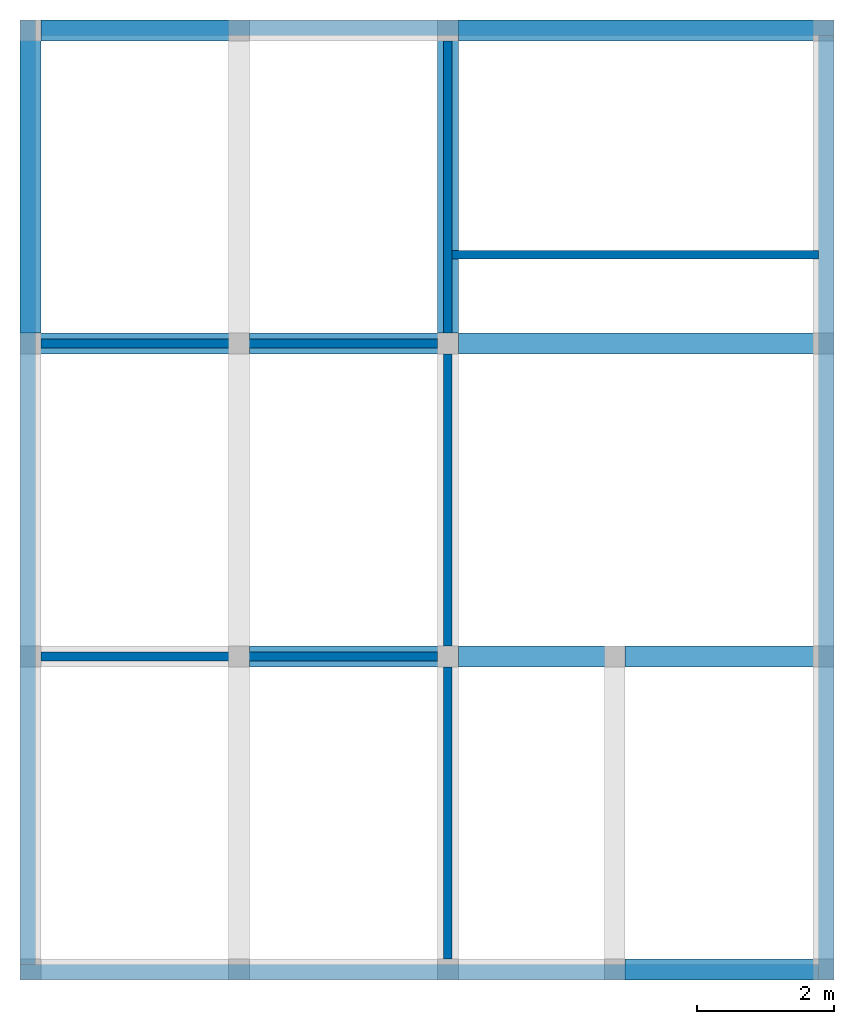
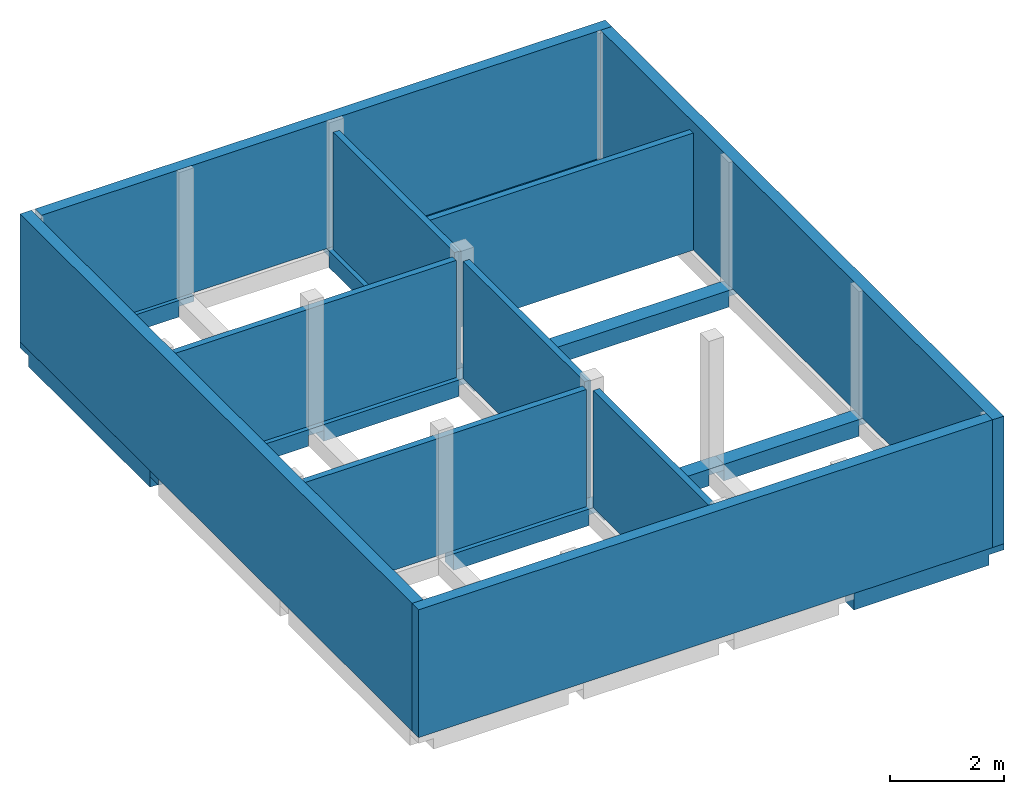
# One storey, part 2 of 2: 11 beams, 10 walls.
"""IFC2X3 building model written with IfcOpenShell, lengths in feet."""

from ifc_helpers import new_model, entity, si_unit, converted_unit, derived_unit, direction, frame, frame_2d, origin, place, context, subcontext, project, spatial, rectangle, extrude, faceted_brep, material, layer, layer_set, layer_usage, type_object, element, save


model = new_model("IFC2X3")

# Units and contexts
model_context = context("Model", 3, precision=0.0001, world=origin(), true_north=direction((6.123031769111886e-17, 1.0)))
body_context = subcontext(model_context, "Body", "Model", "MODEL_VIEW")
ifc_project = project(units=[converted_unit("LENGTHUNIT", "FOOT", entity("IfcLengthMeasure", 0.3048), si_unit("LENGTHUNIT", "METRE"), dimensions=[1, 0, 0, 0, 0, 0, 0]), converted_unit("AREAUNIT", "SQUARE FOOT", entity("IfcAreaMeasure", 0.09290304), si_unit("AREAUNIT", "SQUARE_METRE"), dimensions=[2, 0, 0, 0, 0, 0, 0]), converted_unit("VOLUMEUNIT", "CUBIC FOOT", entity("IfcVolumeMeasure", 0.028316846592000004), si_unit("VOLUMEUNIT", "CUBIC_METRE"), dimensions=[3, 0, 0, 0, 0, 0, 0]), converted_unit("PLANEANGLEUNIT", "DEGREE", entity("IfcPlaneAngleMeasure", 0.017453292519943278), si_unit("PLANEANGLEUNIT", "RADIAN"), dimensions=[0, 0, 0, 0, 0, 0, 0]), si_unit("MASSUNIT", "GRAM", prefix="KILO"), derived_unit("MASSDENSITYUNIT", [(si_unit("MASSUNIT", "GRAM", prefix="KILO"), 1), (si_unit("LENGTHUNIT", "METRE"), -3)]), derived_unit("IONCONCENTRATIONUNIT", [(si_unit("MASSUNIT", "GRAM", prefix="KILO"), 1), (si_unit("LENGTHUNIT", "METRE"), -3)]), derived_unit("MOMENTOFINERTIAUNIT", [(si_unit("LENGTHUNIT", "METRE"), 4)]), si_unit("TIMEUNIT", "SECOND"), si_unit("FREQUENCYUNIT", "HERTZ"), si_unit("THERMODYNAMICTEMPERATUREUNIT", "DEGREE_CELSIUS"), derived_unit("THERMALTRANSMITTANCEUNIT", [(si_unit("MASSUNIT", "GRAM", prefix="KILO"), 1), (si_unit("THERMODYNAMICTEMPERATUREUNIT", "KELVIN"), -1), (si_unit("TIMEUNIT", "SECOND"), -3)]), derived_unit("THERMALCONDUCTANCEUNIT", [(si_unit("MASSUNIT", "GRAM", prefix="KILO"), 1), (si_unit("THERMODYNAMICTEMPERATUREUNIT", "KELVIN"), -1), (si_unit("TIMEUNIT", "SECOND"), -3), (si_unit("LENGTHUNIT", "METRE"), 1)]), derived_unit("VOLUMETRICFLOWRATEUNIT", [(si_unit("LENGTHUNIT", "METRE"), 3), (si_unit("TIMEUNIT", "SECOND"), -1)]), derived_unit("MASSFLOWRATEUNIT", [(si_unit("MASSUNIT", "GRAM", prefix="KILO"), 1), (si_unit("TIMEUNIT", "SECOND"), -1)]), derived_unit("ROTATIONALFREQUENCYUNIT", [(si_unit("TIMEUNIT", "SECOND"), -1)]), si_unit("ELECTRICCURRENTUNIT", "AMPERE"), si_unit("ELECTRICVOLTAGEUNIT", "VOLT"), si_unit("POWERUNIT", "WATT"), converted_unit("FORCEUNIT", "KIP", entity("IfcForceMeasure", 2.088543423315013e-05), si_unit("FORCEUNIT", "NEWTON"), dimensions=[1, 1, -2, 0, 0, 0, 0]), si_unit("ILLUMINANCEUNIT", "LUX"), si_unit("LUMINOUSFLUXUNIT", "LUMEN"), si_unit("LUMINOUSINTENSITYUNIT", "CANDELA"), si_unit("ENERGYUNIT", "JOULE"), derived_unit("USERDEFINED", [(si_unit("MASSUNIT", "GRAM", prefix="KILO"), -1), (si_unit("LENGTHUNIT", "METRE"), -2), (si_unit("TIMEUNIT", "SECOND"), 3), (si_unit("LUMINOUSFLUXUNIT", "LUMEN"), 1)]), derived_unit("USERDEFINED", [(si_unit("MASSUNIT", "GRAM", prefix="KILO"), 1), (si_unit("TIMEUNIT", "SECOND"), -3), (si_unit("LENGTHUNIT", "METRE"), 3), (si_unit("ELECTRICCURRENTUNIT", "AMPERE"), -2)]), derived_unit("SOUNDPOWERUNIT", [(si_unit("MASSUNIT", "GRAM", prefix="KILO"), 1), (si_unit("TIMEUNIT", "SECOND"), -3), (si_unit("LENGTHUNIT", "METRE"), 2)]), derived_unit("SOUNDPRESSUREUNIT", [(si_unit("MASSUNIT", "GRAM", prefix="KILO"), 1), (si_unit("LENGTHUNIT", "METRE"), -1), (si_unit("TIMEUNIT", "SECOND"), -2)]), derived_unit("LINEARVELOCITYUNIT", [(si_unit("LENGTHUNIT", "METRE"), 1), (si_unit("TIMEUNIT", "SECOND"), -1)]), si_unit("PRESSUREUNIT", "PASCAL"), derived_unit("USERDEFINED", [(si_unit("MASSUNIT", "GRAM", prefix="KILO"), 1), (si_unit("LENGTHUNIT", "METRE"), -2), (si_unit("TIMEUNIT", "SECOND"), -2)]), derived_unit("LINEARFORCEUNIT", [(si_unit("MASSUNIT", "GRAM", prefix="KILO"), 1), (si_unit("TIMEUNIT", "SECOND"), -2)]), derived_unit("PLANARFORCEUNIT", [(si_unit("MASSUNIT", "GRAM", prefix="KILO"), 1), (si_unit("LENGTHUNIT", "METRE"), -1), (si_unit("TIMEUNIT", "SECOND"), -2)]), derived_unit("SPECIFICHEATCAPACITYUNIT", [(si_unit("THERMODYNAMICTEMPERATUREUNIT", "KELVIN"), -1), (si_unit("LENGTHUNIT", "METRE"), 2), (si_unit("TIMEUNIT", "SECOND"), -2)]), derived_unit("HEATFLUXDENSITYUNIT", [(si_unit("MASSUNIT", "GRAM", prefix="KILO"), 1), (si_unit("TIMEUNIT", "SECOND"), -3)]), derived_unit("HEATINGVALUEUNIT", [(si_unit("LENGTHUNIT", "METRE"), 2), (si_unit("TIMEUNIT", "SECOND"), -2)]), derived_unit("VAPORPERMEABILITYUNIT", [(si_unit("LENGTHUNIT", "METRE"), -1), (si_unit("TIMEUNIT", "SECOND"), 1)]), derived_unit("DYNAMICVISCOSITYUNIT", [(si_unit("MASSUNIT", "GRAM", prefix="KILO"), 1), (si_unit("TIMEUNIT", "SECOND"), -1), (si_unit("LENGTHUNIT", "METRE"), -1)]), derived_unit("THERMALEXPANSIONCOEFFICIENTUNIT", [(si_unit("THERMODYNAMICTEMPERATUREUNIT", "KELVIN"), -1)]), derived_unit("MODULUSOFELASTICITYUNIT", [(si_unit("MASSUNIT", "GRAM", prefix="KILO"), 1), (si_unit("LENGTHUNIT", "METRE"), -1), (si_unit("TIMEUNIT", "SECOND"), -2)]), derived_unit("ISOTHERMALMOISTURECAPACITYUNIT", [(si_unit("LENGTHUNIT", "METRE"), 3), (si_unit("MASSUNIT", "GRAM", prefix="KILO"), -1)]), derived_unit("MOISTUREDIFFUSIVITYUNIT", [(si_unit("TIMEUNIT", "SECOND"), -1), (si_unit("LENGTHUNIT", "METRE"), 2)]), derived_unit("MASSPERLENGTHUNIT", [(si_unit("MASSUNIT", "GRAM", prefix="KILO"), 1), (si_unit("LENGTHUNIT", "METRE"), -1)]), derived_unit("THERMALRESISTANCEUNIT", [(si_unit("MASSUNIT", "GRAM", prefix="KILO"), -1), (si_unit("TIMEUNIT", "SECOND"), 3), (si_unit("THERMODYNAMICTEMPERATUREUNIT", "KELVIN"), 1)]), derived_unit("ACCELERATIONUNIT", [(si_unit("LENGTHUNIT", "METRE"), 1), (si_unit("TIMEUNIT", "SECOND"), -2)]), derived_unit("ANGULARVELOCITYUNIT", [(si_unit("TIMEUNIT", "SECOND"), -1), (si_unit("PLANEANGLEUNIT", "RADIAN"), 1)]), derived_unit("LINEARSTIFFNESSUNIT", [(si_unit("MASSUNIT", "GRAM", prefix="KILO"), 1), (si_unit("TIMEUNIT", "SECOND"), -2)]), derived_unit("WARPINGCONSTANTUNIT", [(si_unit("LENGTHUNIT", "METRE"), 6)]), derived_unit("LINEARMOMENTUNIT", [(si_unit("MASSUNIT", "GRAM", prefix="KILO"), 1), (si_unit("LENGTHUNIT", "METRE"), 1), (si_unit("TIMEUNIT", "SECOND"), -2)]), derived_unit("TORQUEUNIT", [(si_unit("MASSUNIT", "GRAM", prefix="KILO"), 1), (si_unit("LENGTHUNIT", "METRE"), 2), (si_unit("TIMEUNIT", "SECOND"), -2)])], contexts=[model_context])

# Site, building, storey
site_placement = place(None, origin())
site = spatial("IfcSite", under=ifc_project, at=site_placement, CompositionType="ELEMENT")
building_placement = place(site_placement, origin())
building = spatial("IfcBuilding", under=site, at=building_placement, CompositionType="ELEMENT")
storey_placement = place(building_placement, frame((0.0, 0.0, 9.416666666668288)))
storey = spatial("IfcBuildingStorey", under=building, at=storey_placement, Name="First Floor", CompositionType="ELEMENT", Elevation=9.416666666668288)

# Beams
ifc_material_1 = material(Name="Concrete, Cast-in-Place gray")
beam_type = type_object("IfcBeamType", PredefinedType="NOTDEFINED")
for number, where in (
    (1, (38.37447801916311, -50.34124484724908, -1.1666666666666714)),
    (2, (20.374478019163327, -35.34124484724902, -1.1666666666666714)),
):
    element("IfcBeam", number, at=place(storey_placement, frame(where)), inside=storey, type_object=beam_type, material=ifc_material_1, context=body_context, shape_type="Brep", body=[
        faceted_brep([(10.0, 0.0, 1.1666666666666643), (10.0, 1.0, 1.1666666666666643), (9.0, 1.0, 1.1666666666666643), (0.0, 1.0, 1.1666666666666643), (0.0, 0.0, 1.1666666666666643), (9.0, 0.0, 1.1666666666666643), (0.0, 0.0, 0.7499999999983835), (0.0, 0.0, 0.0), (9.0, 0.0, 0.0), (9.0, 0.0, 0.7499999999983835), (10.0, 0.0, 0.7499999999983835), (0.0, 1.0, 0.0), (9.0, 1.0, 0.0), (10.0, 1.0, 0.7499999999983835), (9.0, 1.0, 0.7499999999983835), (0.0, 1.0, 0.7499999999983835)], [[[0, 1, 2, 3, 4, 5]], [[0, 5, 4, 6, 7, 8, 9, 10]], [[7, 11, 12, 8]], [[3, 2, 1, 13, 14, 12, 11, 15]], [[1, 0, 10, 13]], [[4, 3, 15, 11, 7, 6]], [[14, 9, 8, 12]], [[9, 14, 13, 10]]]),
    ])
beam_1_placement = place(storey_placement, frame((30.37447801916315, -35.34124484724903, -1.1666666666666732)))
element("IfcBeam", 3, at=beam_1_placement, inside=storey, type_object=beam_type, material=ifc_material_1, context=body_context, shape_type="Brep", body=[
    faceted_brep([(8.0, 0.0, 1.166666666666666), (8.0, 1.0, 1.166666666666666), (7.0, 1.0, 1.166666666666666), (0.0, 1.0, 1.166666666666666), (0.0, 0.0, 1.1666666666666679), (7.0, 0.0, 1.1666666666666679), (0.0, 0.0, 0.7499999999983853), (0.0, 0.0, 0.0), (7.0, 0.0, 0.0), (7.0, 0.0, 0.7499999999983853), (8.0, 0.0, 0.7499999999983853), (0.0, 1.0, 0.0), (7.0, 1.0, 0.0), (8.0, 1.0, 0.7499999999983853), (7.0, 1.0, 0.7499999999983853), (0.0, 1.0, 0.7499999999983853)], [[[0, 1, 2, 3, 4, 5]], [[0, 5, 4, 6, 7, 8, 9, 10]], [[7, 11, 12, 8]], [[3, 2, 1, 13, 14, 12, 11, 15]], [[1, 0, 10, 13]], [[4, 3, 15, 11, 7, 6]], [[14, 9, 8, 12]], [[9, 14, 13, 10]]]),
])
beam_2_placement = place(storey_placement, frame((38.37447801916313, -35.34124484724908, -1.1666666666666714)))
element("IfcBeam", 4, at=beam_2_placement, inside=storey, type_object=beam_type, material=ifc_material_1, context=body_context, shape_type="Brep", body=[
    faceted_brep([(10.0, 0.0, 1.1666666666666643), (10.0, 1.0, 1.1666666666666643), (9.0, 1.0, 1.1666666666666643), (0.0, 1.0, 1.1666666666666643), (0.0, 0.0, 1.1666666666666643), (9.0, 0.0, 1.1666666666666643), (0.0, 0.0, 0.7499999999983835), (0.0, 0.0, 0.0), (9.0, 0.0, 0.0), (9.0, 0.0, 0.7499999999983835), (10.0, 0.0, 0.7499999999983835), (0.0, 1.0, 0.0), (9.0, 1.0, 0.0), (10.0, 1.0, 0.7499999999983835), (9.0, 1.0, 0.7499999999983835), (0.0, 1.0, 0.7499999999983835)], [[[0, 1, 2, 3, 4, 5]], [[0, 5, 4, 6, 7, 8, 9, 10]], [[7, 11, 12, 8]], [[3, 2, 1, 13, 14, 12, 11, 15]], [[1, 0, 10, 13]], [[4, 3, 15, 11, 7, 6]], [[14, 9, 8, 12]], [[9, 14, 13, 10]]]),
])
beam_3_placement = place(storey_placement, frame((9.374478019163147, -20.341244847248984, -1.1666666666666714)))
element("IfcBeam", 5, at=beam_3_placement, inside=storey, type_object=beam_type, material=ifc_material_1, context=body_context, shape_type="Brep", body=[
    faceted_brep([(11.0, 0.0, 1.1666666666666643), (11.0, 1.0, 1.1666666666666643), (10.0, 1.0, 1.1666666666666643), (1.0, 1.0, 1.1666666666666643), (0.0, 1.0, 1.1666666666666643), (0.0, 0.0, 1.1666666666666643), (1.0, 0.0, 1.1666666666666643), (10.0, 0.0, 1.1666666666666643), (0.0, 0.0, 0.7499999999983835), (1.0, 0.0, 0.7499999999983835), (1.0, 0.0, 0.0), (10.0, 0.0, 0.0), (10.0, 0.0, 0.7499999999983835), (11.0, 0.0, 0.7499999999983835), (1.0, 1.0, 0.0), (10.0, 1.0, 0.0), (11.0, 1.0, 0.7499999999983835), (10.0, 1.0, 0.7499999999983835), (1.0, 1.0, 0.7499999999983835), (0.0, 1.0, 0.7499999999983835)], [[[0, 1, 2, 3, 4, 5, 6, 7]], [[0, 7, 6, 5, 8, 9, 10, 11, 12, 13]], [[10, 14, 15, 11]], [[4, 3, 2, 1, 16, 17, 15, 14, 18, 19]], [[1, 0, 13, 16]], [[5, 4, 19, 8]], [[9, 18, 14, 10]], [[18, 9, 8, 19]], [[17, 12, 11, 15]], [[12, 17, 16, 13]]]),
])
beam_4_placement = place(storey_placement, frame((20.374478019163355, -20.341244847249012, -1.1666666666666714)))
element("IfcBeam", 6, at=beam_4_placement, inside=storey, type_object=beam_type, material=ifc_material_1, context=body_context, shape_type="Brep", body=[
    faceted_brep([(10.0, 0.0, 1.1666666666666643), (10.0, 1.0, 1.1666666666666643), (9.0, 1.0, 1.1666666666666643), (0.0, 1.0, 1.1666666666666643), (0.0, 0.0, 1.1666666666666643), (9.0, 0.0, 1.1666666666666643), (0.0, 0.0, 0.7499999999983835), (0.0, 0.0, 0.0), (9.0, 0.0, 0.0), (9.0, 0.0, 0.7499999999983835), (10.0, 0.0, 0.7499999999983835), (0.0, 1.0, 0.0), (9.0, 1.0, 0.0), (10.0, 1.0, 0.7499999999983835), (9.0, 1.0, 0.7499999999983835), (0.0, 1.0, 0.7499999999983835)], [[[0, 1, 2, 3, 4, 5]], [[0, 5, 4, 6, 7, 8, 9, 10]], [[7, 11, 12, 8]], [[3, 2, 1, 13, 14, 12, 11, 15]], [[1, 0, 10, 13]], [[4, 3, 15, 11, 7, 6]], [[14, 9, 8, 12]], [[9, 14, 13, 10]]]),
])
beam_5_placement = place(storey_placement, frame((30.374478019163178, -20.341244847249072, -1.1666666666666732)))
element("IfcBeam", 7, at=beam_5_placement, inside=storey, type_object=beam_type, material=ifc_material_1, context=body_context, shape_type="Brep", body=[
    faceted_brep([(18.0, 0.0, 1.166666666666666), (18.0, 1.0, 1.166666666666666), (17.0, 1.0, 1.166666666666666), (0.0, 1.0, 1.166666666666666), (0.0, 0.0, 1.1666666666666679), (17.0, 0.0, 1.1666666666666679), (0.0, 0.0, 0.7499999999983853), (0.0, 0.0, 0.0), (17.0, 0.0, 0.0), (17.0, 0.0, 0.7499999999983853), (18.0, 0.0, 0.7499999999983853), (0.0, 1.0, 0.0), (17.0, 1.0, 0.0), (18.0, 1.0, 0.7499999999983853), (17.0, 1.0, 0.7499999999983853), (0.0, 1.0, 0.7499999999983853)], [[[0, 1, 2, 3, 4, 5]], [[0, 5, 4, 6, 7, 8, 9, 10]], [[7, 11, 12, 8]], [[3, 2, 1, 13, 14, 12, 11, 15]], [[1, 0, 10, 13]], [[4, 3, 15, 11, 7, 6]], [[14, 9, 8, 12]], [[9, 14, 13, 10]]]),
])
for number, where, z_axis, x_axis in (
    (8, (9.374478019162256, -19.34124484724894, -1.1666666666666732), (0.0, 0.0, 1.0), (0.0, -1.0, 0.0)),
    (9, (29.374478019162254, -19.341244847249, -1.1666666666666732), (0.0, 0.0, 1.0), (0.0, -1.0, 0.0)),
):
    element("IfcBeam", number, at=place(storey_placement, frame(where, z_axis=z_axis, x_axis=x_axis)), inside=storey, type_object=beam_type, material=ifc_material_1, context=body_context, shape_type="Brep", body=[
        faceted_brep([(-15.0, 1.0, 1.166666666666666), (-15.0, 0.0, 1.1666666666666679), (-14.0, 0.0, 1.1666666666666679), (0.0, 0.0, 1.166666666666666), (0.0, 1.0, 1.166666666666666), (-14.0, 1.0, 1.166666666666666), (-15.0, 0.0, 0.7499999999983853), (-14.0, 0.0, 0.7499999999983853), (-14.0, 0.0, 0.0), (0.0, 0.0, 0.0), (0.0, 0.0, 0.7499999999983853), (0.0, 1.0, 0.0), (-14.0, 1.0, 0.0), (0.0, 1.0, 0.7499999999983853), (-14.0, 1.0, 0.7499999999983853), (-15.0, 1.0, 0.7499999999983853)], [[[0, 1, 2, 3, 4, 5]], [[3, 2, 1, 6, 7, 8, 9, 10]], [[11, 9, 8, 12]], [[0, 5, 4, 13, 11, 12, 14, 15]], [[1, 0, 15, 6]], [[4, 3, 10, 9, 11, 13]], [[7, 14, 12, 8]], [[14, 7, 6, 15]]]),
    ])
beam_6_placement = place(storey_placement, frame((10.374478019163183, -5.341244847248929, -1.1666666666666714)))
element("IfcBeam", 10, at=beam_6_placement, inside=storey, type_object=beam_type, material=ifc_material_1, context=body_context, shape_type="Brep", body=[
    faceted_brep([(10.0, 0.0, 1.1666666666666643), (10.0, 1.0, 1.1666666666666643), (9.0, 1.0, 1.1666666666666643), (0.0, 1.0, 1.1666666666666643), (0.0, 0.0, 1.1666666666666643), (9.0, 0.0, 1.1666666666666643), (0.0, 0.0, 0.7499999999983835), (0.0, 0.0, 0.0), (9.0, 0.0, 0.0), (9.0, 0.0, 0.7499999999983835), (10.0, 0.0, 0.7499999999983835), (0.0, 1.0, 0.0), (9.0, 1.0, 0.0), (10.0, 1.0, 0.7499999999983835), (9.0, 1.0, 0.7499999999983835), (0.0, 1.0, 0.7499999999983835)], [[[0, 1, 2, 3, 4, 5]], [[0, 5, 4, 6, 7, 8, 9, 10]], [[7, 11, 12, 8]], [[3, 2, 1, 13, 14, 12, 11, 15]], [[1, 0, 10, 13]], [[4, 3, 15, 11, 7, 6]], [[14, 9, 8, 12]], [[9, 14, 13, 10]]]),
])
beam_7_placement = place(storey_placement, frame((30.374478019163202, -5.341244847249021, -1.1666666666666732)))
element("IfcBeam", 11, at=beam_7_placement, inside=storey, type_object=beam_type, material=ifc_material_1, context=body_context, shape_type="Brep", body=[
    faceted_brep([(18.0, 0.0, 1.166666666666666), (18.0, 1.0, 1.166666666666666), (17.0, 1.0, 1.166666666666666), (0.0, 1.0, 1.166666666666666), (0.0, 0.0, 1.1666666666666679), (17.0, 0.0, 1.1666666666666679), (0.0, 0.0, 0.7499999999983853), (0.0, 0.0, 0.0), (17.0, 0.0, 0.0), (17.0, 0.0, 0.7499999999983853), (18.0, 0.0, 0.7499999999983853), (0.0, 1.0, 0.0), (17.0, 1.0, 0.0), (18.0, 1.0, 0.7499999999983853), (17.0, 1.0, 0.7499999999983853), (0.0, 1.0, 0.7499999999983853)], [[[0, 1, 2, 3, 4, 5]], [[0, 5, 4, 6, 7, 8, 9, 10]], [[7, 11, 12, 8]], [[3, 2, 1, 13, 14, 12, 11, 15]], [[1, 0, 10, 13]], [[4, 3, 15, 11, 7, 6]], [[14, 9, 8, 12]], [[9, 14, 13, 10]]]),
])

# Walls
ifc_material_2 = material(Name="Default Wall")
ifc_layer_1 = layer(ifc_material_2, 0.75)
ifc_layer_set_1 = layer_set([ifc_layer_1])
ifc_layer_usage_1 = layer_usage(ifc_layer_set_1, "AXIS2", "NEGATIVE", 0.375)
wall_type_1 = type_object("IfcWallType", PredefinedType="STANDARD", material=ifc_layer_set_1)
wall_1_placement = place(storey_placement, frame((10.37447801916223, -4.716244847248886, 0.0)))
element("IfcWallStandardCase", 12, at=wall_1_placement, inside=storey, type_object=wall_type_1, material=ifc_layer_usage_1, context=body_context, shape_type="SweptSolid", body=[
    extrude(rectangle(XDim=38.00000000000001, YDim=0.75, at=frame_2d((19.000000000000004, 0.0), x_axis=(-1.0, 0.0))), origin(), (0.0, 0.0, 1.0), 8.999999999998618),
])
wall_2_placement = place(storey_placement, frame((47.99947801916224, -5.091244847249007, 0.0), z_axis=(0.0, 0.0, 1.0), x_axis=(0.0, -1.0, 0.0)))
element("IfcWallStandardCase", 13, at=wall_2_placement, inside=storey, type_object=wall_type_1, material=ifc_layer_usage_1, context=body_context, shape_type="SweptSolid", body=[
    extrude(rectangle(XDim=45.25000000000005, YDim=0.75, at=frame_2d((22.625000000000025, -5.828670879282072e-16), x_axis=(-1.0, 0.0))), origin(), (0.0, 0.0, 1.0), 8.999999999998618),
])
wall_3_placement = place(storey_placement, frame((47.62447801916217, -49.96624484724906, 0.0), z_axis=(0.0, 0.0, 1.0), x_axis=(-1.0, 0.0, 0.0)))
element("IfcWallStandardCase", 14, at=wall_3_placement, inside=storey, type_object=wall_type_1, material=ifc_layer_usage_1, context=body_context, shape_type="SweptSolid", body=[
    extrude(rectangle(XDim=38.25000000000001, YDim=0.75, at=frame_2d((19.125000000000004, -1.2212453270876722e-15), x_axis=(-1.0, 0.0))), origin(), (0.0, 0.0, 1.0), 8.999999999998618),
])
wall_4_placement = place(storey_placement, frame((9.749478019162163, -49.59124484724893, 0.0), z_axis=(0.0, 0.0, 1.0), x_axis=(0.0, 1.0, 0.0)))
element("IfcWallStandardCase", 15, at=wall_4_placement, inside=storey, type_object=wall_type_1, material=ifc_layer_usage_1, context=body_context, shape_type="SweptSolid", body=[
    extrude(rectangle(XDim=45.25000000000005, YDim=0.75, at=frame_2d((22.625000000000025, 2.7755575615628914e-16), x_axis=(-1.0, 0.0))), origin(), (0.0, 0.0, 1.0), 8.999999999998618),
])
ifc_layer_2 = layer(ifc_material_2, 0.4166666666666667)
ifc_layer_set_2 = layer_set([ifc_layer_2])
ifc_layer_usage_2 = layer_usage(ifc_layer_set_2, "AXIS2", "NEGATIVE", 0.20833333333333334)
wall_type_2 = type_object("IfcWallType", PredefinedType="STANDARD", material=ifc_layer_set_2)
wall_5_placement = place(storey_placement, frame((10.37447801916221, -19.841244847248937, 0.0)))
element("IfcWallStandardCase", 16, at=wall_5_placement, inside=storey, type_object=wall_type_2, material=ifc_layer_usage_2, context=body_context, shape_type="SweptSolid", body=[
    extrude(rectangle(XDim=19.0, YDim=0.4166666666666643, at=frame_2d((9.5, 0.0), x_axis=(-1.0, 0.0))), origin(), (0.0, 0.0, 1.0), 8.249999999998618),
])
wall_6_placement = place(storey_placement, frame((29.87447801916221, -19.341244847248994, 0.0), z_axis=(0.0, 0.0, 1.0), x_axis=(0.0, 1.0, 0.0)))
element("IfcWallStandardCase", 17, at=wall_6_placement, inside=storey, type_object=wall_type_2, material=ifc_layer_usage_2, context=body_context, shape_type="SweptSolid", body=[
    extrude(rectangle(XDim=14.000000000000046, YDim=0.4166666666666643, at=frame_2d((7.000000000000023, 0.0), x_axis=(-1.0, 0.0))), origin(), (0.0, 0.0, 1.0), 8.249999999998618),
])
wall_7_placement = place(storey_placement, frame((29.87447801916221, -20.341244847249, 0.0), z_axis=(0.0, 0.0, 1.0), x_axis=(0.0, -1.0, 0.0)))
element("IfcWallStandardCase", 18, at=wall_7_placement, inside=storey, type_object=wall_type_2, material=ifc_layer_usage_2, context=body_context, shape_type="SweptSolid", body=[
    extrude(rectangle(XDim=13.999999999999986, YDim=0.4166666666666643, at=frame_2d((6.999999999999993, 0.0), x_axis=(-1.0, 0.0))), origin(), (0.0, 0.0, 1.0), 8.249999999998618),
])
wall_8_placement = place(storey_placement, frame((29.37447801916219, -34.841244847248994, 0.0), z_axis=(0.0, 0.0, 1.0), x_axis=(-1.0, 0.0, 0.0)))
element("IfcWallStandardCase", 19, at=wall_8_placement, inside=storey, type_object=wall_type_2, material=ifc_layer_usage_2, context=body_context, shape_type="SweptSolid", body=[
    extrude(rectangle(XDim=19.000000000000007, YDim=0.4166666666666714, at=frame_2d((9.500000000000004, 0.0), x_axis=(-1.0, 0.0))), origin(), (0.0, 0.0, 1.0), 8.249999999998618),
])
wall_9_placement = place(storey_placement, frame((29.87447801916219, -35.341244847249, 0.0), z_axis=(0.0, 0.0, 1.0), x_axis=(0.0, -1.0, 0.0)))
element("IfcWallStandardCase", 20, at=wall_9_placement, inside=storey, type_object=wall_type_2, material=ifc_layer_usage_2, context=body_context, shape_type="SweptSolid", body=[
    extrude(rectangle(XDim=13.999999999999986, YDim=0.4166666666666643, at=frame_2d((6.999999999999993, 0.0), x_axis=(-1.0, 0.0))), origin(), (0.0, 0.0, 1.0), 8.249999999998618),
])
wall_10_placement = place(storey_placement, frame((30.082811352495554, -15.591244847248992, 0.0)))
element("IfcWallStandardCase", 21, at=wall_10_placement, inside=storey, type_object=wall_type_2, material=ifc_layer_usage_2, context=body_context, shape_type="SweptSolid", body=[
    extrude(rectangle(XDim=17.54166666666667, YDim=0.41666666666666785, at=frame_2d((8.770833333333336, 0.0), x_axis=(-1.0, 0.0))), origin(), (0.0, 0.0, 1.0), 8.249999999998618),
])

save(model, "model.ifc")
